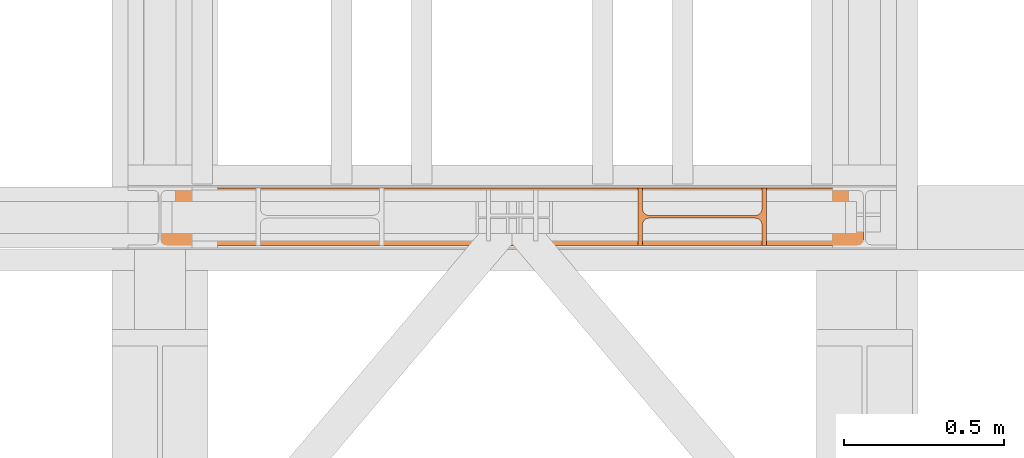
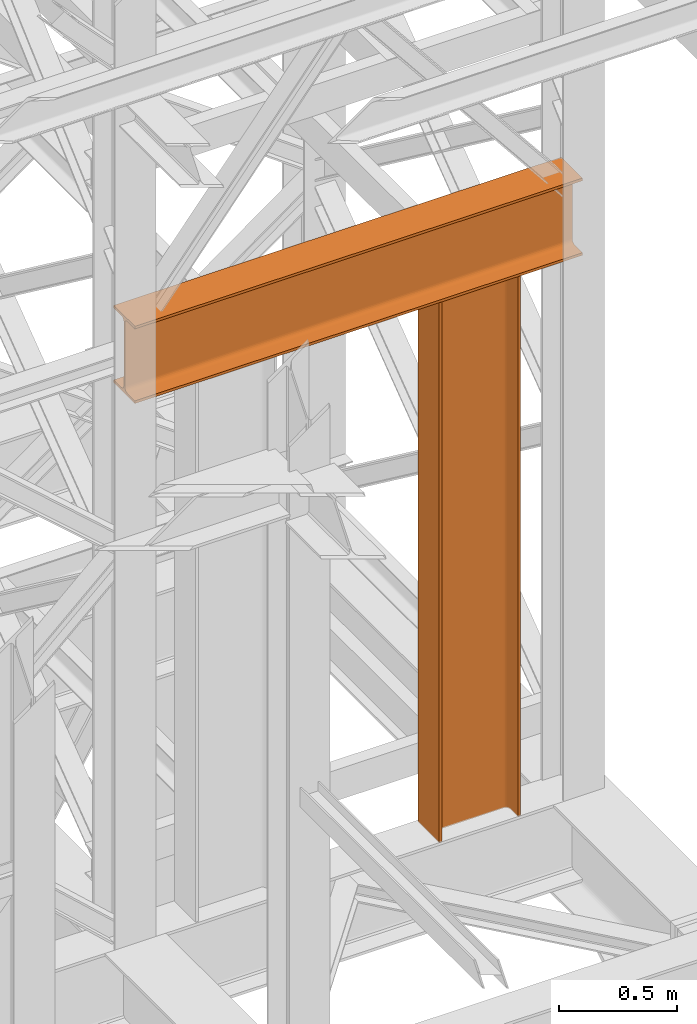
# One storey, part 177 of 208: 2 proxies.
"""IFC2X3 building model written with IfcOpenShell, lengths in millimetres."""

from ifc_helpers import new_model, entity, si_unit, converted_unit, frame, origin, origin_with_axes, place, context, subcontext, project, spatial, faceted_brep, element, save


model = new_model("IFC2X3")

# Units and contexts
model_context = context("Model", 3, precision=1e-05, world=origin())
plan_context = context("Plan", 3, precision=1e-05, world=origin())
body_context = subcontext(model_context, "Body", "Model", "MODEL_VIEW")
ifc_project = project(units=[si_unit("LENGTHUNIT", "METRE", prefix="MILLI"), converted_unit("PLANEANGLEUNIT", "DEGREE", entity("IfcPlaneAngleMeasure", 0.0174532925199433), si_unit("PLANEANGLEUNIT", "RADIAN"), dimensions=[0, 0, 0, 0, 0, 0, 0]), si_unit("AREAUNIT", "SQUARE_METRE"), si_unit("VOLUMEUNIT", "CUBIC_METRE")], contexts=[model_context, plan_context])

# Building, storey
building_placement = place(None, origin())
building = spatial("IfcBuilding", under=ifc_project, at=building_placement, CompositionType="COMPLEX")
storey_placement = place(building_placement, origin_with_axes())
storey = spatial("IfcBuildingStorey", under=building, at=storey_placement, Name="Geschoss", CompositionType="ELEMENT")

# Proxies
proxy_1_placement = place(storey_placement, frame((8086.754968394562, -16050.07439031789, 5278.356417081654), z_axis=(0.0, 0.0, 1.0), x_axis=(1.0, 0.0, 0.0)))
element("IfcBuildingElementProxy", 1, at=proxy_1_placement, inside=storey, context=body_context, shape_type="Brep", body=[
    faceted_brep([(0.01000000000021828, 180.0100000000002, 0.01000000000112777), (13.51000000000022, 180.0100000000002, 0.01000000000112777), (13.51000000000022, 180.0100000000002, 2800.009999999993), (0.01000000000021828, 180.0100000000002, 2800.009999999993), (13.51000000000022, 180.0100000000002, 0.01000000000112777), (13.51000000000022, 115.3100001907351, 0.01000000000112777), (13.51000000000022, 115.3100001907351, 2800.009999999993), (13.51000000000022, 180.0100000000002, 2800.009999999993), (13.51000000000022, 115.3100001907351, 0.01000000000112777), (14.53788471157623, 108.820665321733, 0.01000000000112777), (14.53788471157623, 108.820665321733, 2800.009999999993), (13.51000000000022, 115.3100001907351, 2800.009999999993), (14.53788471157623, 108.820665321733, 0.01000000000112777), (17.52066908402048, 102.9665306951119, 0.01000000000112777), (17.52066908402048, 102.9665306951119, 2800.009999999993), (14.53788471157623, 108.820665321733, 2800.009999999993), (17.52066908402048, 102.9665306951119, 0.01000000000112777), (22.16653050437617, 98.32066927475717, 0.01000000000112777), (22.16653050437617, 98.32066927475717, 2800.009999999993), (17.52066908402048, 102.9665306951119, 2800.009999999993), (22.16653050437617, 98.32066927475717, 0.01000000000112777), (28.02066513099726, 95.337884902312, 0.01000000000112777), (28.02066513099726, 95.337884902312, 2800.009999999993), (22.16653050437617, 98.32066927475717, 2800.009999999993), (28.02066513099726, 95.337884902312, 0.01000000000112777), (34.51000000000022, 94.31000019073508, 0.01000000000112777), (34.51000000000022, 94.31000019073508, 2800.009999999993), (28.02066513099726, 95.337884902312, 2800.009999999993), (34.51000000000022, 94.31000019073508, 0.01000000000112777), (365.5100000000002, 94.31000019073508, 0.01000000000021828), (365.5100000000002, 94.31000019073508, 2800.009999999993), (34.51000000000022, 94.31000019073508, 2800.009999999993), (365.5100000000002, 94.31000019073508, 0.01000000000021828), (371.9993348690023, 95.337884902312, 0.01000000000021828), (371.9993348690023, 95.337884902312, 2800.009999999993), (365.5100000000002, 94.31000019073508, 2800.009999999993), (371.9993348690023, 95.337884902312, 0.01000000000021828), (377.8534694956234, 98.32066927475717, 0.01000000000021828), (377.8534694956234, 98.32066927475717, 2800.009999999993), (371.9993348690023, 95.337884902312, 2800.009999999993), (377.8534694956234, 98.32066927475717, 0.01000000000021828), (382.49933091598, 102.9665306951119, 0.01000000000021828), (382.49933091598, 102.9665306951119, 2800.009999999993), (377.8534694956234, 98.32066927475717, 2800.009999999993), (382.49933091598, 102.9665306951119, 0.01000000000021828), (385.4821152884251, 108.820665321733, 0.01000000000021828), (385.4821152884251, 108.820665321733, 2800.009999999993), (382.49933091598, 102.9665306951119, 2800.009999999993), (385.4821152884251, 108.820665321733, 0.01000000000021828), (386.5100000000002, 115.3100001907351, 0.01000000000021828), (386.5100000000002, 115.3100001907351, 2800.009999999993), (385.4821152884251, 108.820665321733, 2800.009999999993), (386.5100000000002, 115.3100001907351, 0.01000000000021828), (386.5100000000002, 180.0100000000002, 0.01000000000021828), (386.5100000000002, 180.0100000000002, 2800.009999999993), (386.5100000000002, 115.3100001907351, 2800.009999999993), (386.5100000000002, 180.0100000000002, 0.01000000000021828), (400.0100000000002, 180.0100000000002, 0.01000000000021828), (400.0100000000002, 180.0100000000002, 2800.009999999993), (386.5100000000002, 180.0100000000002, 2800.009999999993), (400.0100000000002, 180.0100000000002, 0.01000000000021828), (400.0100000000002, 0.01000000000021828, 0.01000000000021828), (400.0100000000002, 0.01000000000021828, 2800.009999999993), (400.0100000000002, 180.0100000000002, 2800.009999999993), (400.0100000000002, 0.01000000000021828, 0.01000000000021828), (386.5100000000002, 0.01000000000021828, 0.01000000000021828), (386.5100000000002, 0.01000000000021828, 2800.009999999993), (400.0100000000002, 0.01000000000021828, 2800.009999999993), (386.5100000000002, 0.01000000000021828, 0.01000000000021828), (386.5100000000002, 64.70999980926535, 0.01000000000021828), (386.5100000000002, 64.70999980926535, 2800.009999999993), (386.5100000000002, 0.01000000000021828, 2800.009999999993), (386.5100000000002, 64.70999980926535, 0.01000000000021828), (385.4821152884251, 71.1993346782674, 0.01000000000021828), (385.4821152884251, 71.1993346782674, 2800.009999999993), (386.5100000000002, 64.70999980926535, 2800.009999999993), (385.4821152884251, 71.1993346782674, 0.01000000000021828), (382.49933091598, 77.0534693048885, 0.01000000000021828), (382.49933091598, 77.0534693048885, 2800.009999999993), (385.4821152884251, 71.1993346782674, 2800.009999999993), (382.49933091598, 77.0534693048885, 0.01000000000021828), (377.8534694956234, 81.69933072524327, 0.01000000000021828), (377.8534694956234, 81.69933072524327, 2800.009999999993), (382.49933091598, 77.0534693048885, 2800.009999999993), (377.8534694956234, 81.69933072524327, 0.01000000000021828), (371.9993348690023, 84.68211509768844, 0.01000000000021828), (371.9993348690023, 84.68211509768844, 2800.009999999993), (377.8534694956234, 81.69933072524327, 2800.009999999993), (371.9993348690023, 84.68211509768844, 0.01000000000021828), (365.5100000000002, 85.70999980926535, 0.01000000000021828), (365.5100000000002, 85.70999980926535, 2800.009999999993), (371.9993348690023, 84.68211509768844, 2800.009999999993), (365.5100000000002, 85.70999980926535, 0.01000000000021828), (34.51000000000022, 85.70999980926535, 0.01000000000112777), (34.51000000000022, 85.70999980926535, 2800.009999999993), (365.5100000000002, 85.70999980926535, 2800.009999999993), (34.51000000000022, 85.70999980926535, 0.01000000000112777), (29.07481828161781, 84.99438062176887, 0.01000000000112777), (29.07481828161781, 84.99438062176887, 2800.009999999993), (34.51000000000022, 85.70999980926535, 2800.009999999993), (29.07481828161781, 84.99438062176887, 0.01000000000112777), (24.01003062535619, 82.89647688400692, 0.01000000000112777), (24.01003062535619, 82.89647688400692, 2800.009999999993), (29.07481828161781, 84.99438062176887, 2800.009999999993), (24.01003062535619, 82.89647688400692, 0.01000000000112777), (19.66075759508203, 79.55924221418354, 0.01000000000112777), (19.66075759508203, 79.55924221418354, 2800.009999999993), (24.01003062535619, 82.89647688400692, 2800.009999999993), (19.66075759508203, 79.55924221418354, 0.01000000000112777), (16.32352292525866, 75.20996918390847, 0.01000000000112777), (16.32352292525866, 75.20996918390847, 2800.009999999993), (19.66075759508203, 79.55924221418354, 2800.009999999993), (16.32352292525866, 75.20996918390847, 0.01000000000112777), (14.22561918749489, 70.14518152764686, 0.01000000000112777), (14.22561918749489, 70.14518152764686, 2800.009999999993), (16.32352292525866, 75.20996918390847, 2800.009999999993), (14.22561918749489, 70.14518152764686, 0.01000000000112777), (13.51000000000022, 64.70999980926535, 0.01000000000112777), (13.51000000000022, 64.70999980926535, 2800.009999999993), (14.22561918749489, 70.14518152764686, 2800.009999999993), (13.51000000000022, 64.70999980926535, 0.01000000000112777), (13.51000000000022, 0.01000000000021828, 0.01000000000112777), (13.51000000000022, 0.01000000000021828, 2800.009999999993), (13.51000000000022, 64.70999980926535, 2800.009999999993), (13.51000000000022, 0.01000000000021828, 0.01000000000112777), (0.01000000000021828, 0.01000000000021828, 0.01000000000112777), (0.01000000000021828, 0.01000000000021828, 2800.009999999993), (13.51000000000022, 0.01000000000021828, 2800.009999999993), (0.01000000000021828, 0.01000000000021828, 0.01000000000112777), (0.01000000000021828, 180.0100000000002, 0.01000000000112777), (0.01000000000021828, 180.0100000000002, 2800.009999999993), (0.01000000000021828, 0.01000000000021828, 2800.009999999993), (0.01000000000021828, 180.0100000000002, 0.01000000000112777), (0.01000000000021828, 0.01000000000021828, 0.01000000000112777), (13.51000000000022, 0.01000000000021828, 0.01000000000112777), (13.51000000000022, 64.70999980926535, 0.01000000000112777), (14.22561918749489, 70.14518152764686, 0.01000000000112777), (16.32352292525866, 75.20996918390847, 0.01000000000112777), (19.66075759508203, 79.55924221418354, 0.01000000000112777), (24.01003062535619, 82.89647688400692, 0.01000000000112777), (29.07481828161781, 84.99438062176887, 0.01000000000112777), (34.51000000000022, 85.70999980926535, 0.01000000000112777), (365.5100000000002, 85.70999980926535, 0.01000000000021828), (371.9993348690023, 84.68211509768844, 0.01000000000021828), (377.8534694956234, 81.69933072524327, 0.01000000000021828), (382.49933091598, 77.0534693048885, 0.01000000000021828), (385.4821152884251, 71.1993346782674, 0.01000000000021828), (386.5100000000002, 64.70999980926535, 0.01000000000021828), (386.5100000000002, 0.01000000000021828, 0.01000000000021828), (400.0100000000002, 0.01000000000021828, 0.01000000000021828), (400.0100000000002, 180.0100000000002, 0.01000000000021828), (386.5100000000002, 180.0100000000002, 0.01000000000021828), (386.5100000000002, 115.3100001907351, 0.01000000000021828), (385.4821152884251, 108.820665321733, 0.01000000000021828), (382.49933091598, 102.9665306951119, 0.01000000000021828), (377.8534694956234, 98.32066927475717, 0.01000000000021828), (371.9993348690023, 95.337884902312, 0.01000000000021828), (365.5100000000002, 94.31000019073508, 0.01000000000021828), (34.51000000000022, 94.31000019073508, 0.01000000000112777), (28.02066513099726, 95.337884902312, 0.01000000000112777), (22.16653050437617, 98.32066927475717, 0.01000000000112777), (17.52066908402048, 102.9665306951119, 0.01000000000112777), (14.53788471157623, 108.820665321733, 0.01000000000112777), (13.51000000000022, 115.3100001907351, 0.01000000000112777), (13.51000000000022, 180.0100000000002, 0.01000000000112777), (0.01000000000021828, 180.0100000000002, 2800.009999999993), (13.51000000000022, 180.0100000000002, 2800.009999999993), (13.51000000000022, 115.3100001907351, 2800.009999999993), (14.53788471157623, 108.820665321733, 2800.009999999993), (17.52066908402048, 102.9665306951119, 2800.009999999993), (22.16653050437617, 98.32066927475717, 2800.009999999993), (28.02066513099726, 95.337884902312, 2800.009999999993), (34.51000000000022, 94.31000019073508, 2800.009999999993), (365.5100000000002, 94.31000019073508, 2800.009999999993), (371.9993348690023, 95.337884902312, 2800.009999999993), (377.8534694956234, 98.32066927475717, 2800.009999999993), (382.49933091598, 102.9665306951119, 2800.009999999993), (385.4821152884251, 108.820665321733, 2800.009999999993), (386.5100000000002, 115.3100001907351, 2800.009999999993), (386.5100000000002, 180.0100000000002, 2800.009999999993), (400.0100000000002, 180.0100000000002, 2800.009999999993), (400.0100000000002, 0.01000000000021828, 2800.009999999993), (386.5100000000002, 0.01000000000021828, 2800.009999999993), (386.5100000000002, 64.70999980926535, 2800.009999999993), (385.4821152884251, 71.1993346782674, 2800.009999999993), (382.49933091598, 77.0534693048885, 2800.009999999993), (377.8534694956234, 81.69933072524327, 2800.009999999993), (371.9993348690023, 84.68211509768844, 2800.009999999993), (365.5100000000002, 85.70999980926535, 2800.009999999993), (34.51000000000022, 85.70999980926535, 2800.009999999993), (29.07481828161781, 84.99438062176887, 2800.009999999993), (24.01003062535619, 82.89647688400692, 2800.009999999993), (19.66075759508203, 79.55924221418354, 2800.009999999993), (16.32352292525866, 75.20996918390847, 2800.009999999993), (14.22561918749489, 70.14518152764686, 2800.009999999993), (13.51000000000022, 64.70999980926535, 2800.009999999993), (13.51000000000022, 0.01000000000021828, 2800.009999999993), (0.01000000000021828, 0.01000000000021828, 2800.009999999993)], [[[0, 1, 2, 3]], [[4, 5, 6, 7]], [[8, 9, 10, 11]], [[12, 13, 14, 15]], [[16, 17, 18, 19]], [[20, 21, 22, 23]], [[24, 25, 26, 27]], [[28, 29, 30, 31]], [[32, 33, 34, 35]], [[36, 37, 38, 39]], [[40, 41, 42, 43]], [[44, 45, 46, 47]], [[48, 49, 50, 51]], [[52, 53, 54, 55]], [[56, 57, 58, 59]], [[60, 61, 62, 63]], [[64, 65, 66, 67]], [[68, 69, 70, 71]], [[72, 73, 74, 75]], [[76, 77, 78, 79]], [[80, 81, 82, 83]], [[84, 85, 86, 87]], [[88, 89, 90, 91]], [[92, 93, 94, 95]], [[96, 97, 98, 99]], [[100, 101, 102, 103]], [[104, 105, 106, 107]], [[108, 109, 110, 111]], [[112, 113, 114, 115]], [[116, 117, 118, 119]], [[120, 121, 122, 123]], [[124, 125, 126, 127]], [[128, 129, 130, 131]], [[132, 133, 134, 135, 136, 137, 138, 139, 140, 141, 142, 143, 144, 145, 146, 147, 148, 149, 150, 151, 152, 153, 154, 155, 156, 157, 158, 159, 160, 161, 162, 163, 164]], [[165, 166, 167, 168, 169, 170, 171, 172, 173, 174, 175, 176, 177, 178, 179, 180, 181, 182, 183, 184, 185, 186, 187, 188, 189, 190, 191, 192, 193, 194, 195, 196, 197]]], orient=[[False], [False], [False], [False], [False], [False], [False], [False], [False], [False], [False], [False], [False], [False], [False], [False], [False], [False], [False], [False], [False], [False], [False], [False], [False], [False], [False], [False], [False], [False], [False], [False], [False], [False], [False]]),
])
proxy_2_placement = place(storey_placement, frame((6595.42496483591, -16050.07439031789, 8078.356417081646), z_axis=(0.0, 0.0, 1.0), x_axis=(1.0, 0.0, 0.0)))
element("IfcBuildingElementProxy", 2, at=proxy_2_placement, inside=storey, context=body_context, shape_type="Brep", body=[
    faceted_brep([(2194.590003625702, 180.0100000000002, 400.0100000000002), (0.01000000000021828, 180.0100000000002, 400.0100000000002), (0.01000000000021828, 180.0100000000002, 386.5100000000002), (2194.590003625702, 180.0100000000002, 386.5100000000002), (2194.590003625702, 180.0100000000002, 386.5100000000002), (0.01000000000021828, 180.0100000000002, 386.5100000000002), (0.01000000000021828, 115.3100001907351, 386.5100000000002), (2194.590003625702, 115.3100001907351, 386.5100000000002), (2194.590003625702, 115.3100001907351, 386.5100000000002), (0.01000000000021828, 115.3100001907351, 386.5100000000002), (0.01000000000021828, 108.820665321733, 385.4821152884251), (2194.590003625702, 108.820665321733, 385.4821152884233), (2194.590003625702, 108.820665321733, 385.4821152884233), (0.01000000000021828, 108.820665321733, 385.4821152884251), (0.01000000000021828, 102.9665306951119, 382.4993309159818), (2194.590003625702, 102.9665306951119, 382.49933091598), (2194.590003625702, 102.9665306951119, 382.49933091598), (0.01000000000021828, 102.9665306951119, 382.4993309159818), (0.01000000000021828, 98.32066927475717, 377.8534694956252), (2194.590003625702, 98.32066927475717, 377.8534694956234), (2194.590003625702, 98.32066927475717, 377.8534694956234), (0.01000000000021828, 98.32066927475717, 377.8534694956252), (0.01000000000021828, 95.337884902312, 371.9993348690041), (2194.590003625702, 95.337884902312, 371.9993348690023), (2194.590003625702, 95.337884902312, 371.9993348690023), (0.01000000000021828, 95.337884902312, 371.9993348690041), (0.01000000000021828, 94.31000019073508, 365.5100000000002), (2194.590003625702, 94.31000019073508, 365.5100000000002), (2194.590003625702, 94.31000019073508, 365.5100000000002), (0.01000000000021828, 94.31000019073508, 365.5100000000002), (0.01000000000021828, 94.31000019073508, 34.51000000000113), (2194.590003625702, 94.31000019073508, 34.51000000000022), (2194.590003625702, 94.31000019073508, 34.51000000000022), (0.01000000000021828, 94.31000019073508, 34.51000000000113), (0.01000000000021828, 95.337884902312, 28.02066513099908), (2194.590003625702, 95.337884902312, 28.02066513099817), (2194.590003625702, 95.337884902312, 28.02066513099817), (0.01000000000021828, 95.337884902312, 28.02066513099908), (0.01000000000021828, 98.32066927475717, 22.16653050437799), (2194.590003625702, 98.32066927475717, 22.16653050437708), (2194.590003625702, 98.32066927475717, 22.16653050437708), (0.01000000000021828, 98.32066927475717, 22.16653050437799), (0.01000000000021828, 102.9665306951119, 17.5206690840223), (2194.590003625702, 102.9665306951119, 17.52066908402139), (2194.590003625702, 102.9665306951119, 17.52066908402139), (0.01000000000021828, 102.9665306951119, 17.5206690840223), (0.01000000000021828, 108.820665321733, 14.53788471157714), (2194.590003625702, 108.820665321733, 14.53788471157623), (2194.590003625702, 108.820665321733, 14.53788471157623), (0.01000000000021828, 108.820665321733, 14.53788471157714), (0.01000000000021828, 115.3100001907351, 13.51000000000113), (2194.590003625702, 115.3100001907351, 13.51000000000022), (2194.590003625702, 115.3100001907351, 13.51000000000022), (0.01000000000021828, 115.3100001907351, 13.51000000000113), (0.01000000000021828, 180.0100000000002, 13.51000000000113), (2194.590003625702, 180.0100000000002, 13.51000000000022), (2194.590003625702, 180.0100000000002, 13.51000000000022), (0.01000000000021828, 180.0100000000002, 13.51000000000113), (0.01000000000021828, 180.0100000000002, 0.01000000000112777), (2194.590003625702, 180.0100000000002, 0.01000000000021828), (2194.590003625702, 180.0100000000002, 0.01000000000021828), (0.01000000000021828, 180.0100000000002, 0.01000000000112777), (0.01000000000021828, 0.01000000000021828, 0.01000000000112777), (2194.590003625702, 0.01000000000021828, 0.01000000000021828), (2194.590003625702, 0.01000000000021828, 0.01000000000021828), (0.01000000000021828, 0.01000000000021828, 0.01000000000112777), (0.01000000000021828, 0.01000000000021828, 13.51000000000113), (2194.590003625702, 0.01000000000021828, 13.51000000000022), (2194.590003625702, 0.01000000000021828, 13.51000000000022), (0.01000000000021828, 0.01000000000021828, 13.51000000000113), (0.01000000000021828, 64.70999980926535, 13.51000000000113), (2194.590003625702, 64.70999980926535, 13.51000000000022), (2194.590003625702, 64.70999980926535, 13.51000000000022), (0.01000000000021828, 64.70999980926535, 13.51000000000113), (0.01000000000021828, 71.1993346782674, 14.53788471157714), (2194.590003625702, 71.1993346782674, 14.53788471157623), (2194.590003625702, 71.1993346782674, 14.53788471157623), (0.01000000000021828, 71.1993346782674, 14.53788471157714), (0.01000000000021828, 77.0534693048885, 17.5206690840223), (2194.590003625702, 77.0534693048885, 17.52066908402139), (2194.590003625702, 77.0534693048885, 17.52066908402139), (0.01000000000021828, 77.0534693048885, 17.5206690840223), (0.01000000000021828, 81.69933072524327, 22.16653050437799), (2194.590003625702, 81.69933072524327, 22.16653050437708), (2194.590003625702, 81.69933072524327, 22.16653050437708), (0.01000000000021828, 81.69933072524327, 22.16653050437799), (0.01000000000021828, 84.68211509768844, 28.02066513099908), (2194.590003625702, 84.68211509768844, 28.02066513099817), (2194.590003625702, 84.68211509768844, 28.02066513099817), (0.01000000000021828, 84.68211509768844, 28.02066513099908), (0.01000000000021828, 85.70999980926535, 34.51000000000113), (2194.590003625702, 85.70999980926535, 34.51000000000022), (2194.590003625702, 85.70999980926535, 34.51000000000022), (0.01000000000021828, 85.70999980926535, 34.51000000000113), (0.01000000000021828, 85.70999980926535, 365.5100000000002), (2194.590003625702, 85.70999980926535, 365.5100000000002), (2194.590003625702, 85.70999980926535, 365.5100000000002), (0.01000000000021828, 85.70999980926535, 365.5100000000002), (0.01000000000021828, 84.99438062176887, 370.9451817183835), (2194.590003625702, 84.99438062176887, 370.9451817183817), (2194.590003625702, 84.99438062176887, 370.9451817183817), (0.01000000000021828, 84.99438062176887, 370.9451817183835), (0.01000000000021828, 82.89647688400692, 376.0099693746452), (2194.590003625702, 82.89647688400692, 376.0099693746433), (2194.590003625702, 82.89647688400692, 376.0099693746433), (0.01000000000021828, 82.89647688400692, 376.0099693746452), (0.01000000000021828, 79.55924221418354, 380.3592424049184), (2194.590003625702, 79.55924221418354, 380.3592424049184), (2194.590003625702, 79.55924221418354, 380.3592424049184), (0.01000000000021828, 79.55924221418354, 380.3592424049184), (0.01000000000021828, 75.20996918390847, 383.6964770747418), (2194.590003625702, 75.20996918390847, 383.6964770747418), (2194.590003625702, 75.20996918390847, 383.6964770747418), (0.01000000000021828, 75.20996918390847, 383.6964770747418), (0.01000000000021828, 70.14518152764686, 385.7943808125074), (2194.590003625702, 70.14518152764686, 385.7943808125056), (2194.590003625702, 70.14518152764686, 385.7943808125056), (0.01000000000021828, 70.14518152764686, 385.7943808125074), (0.01000000000021828, 64.70999980926535, 386.5100000000002), (2194.590003625702, 64.70999980926535, 386.5100000000002), (2194.590003625702, 64.70999980926535, 386.5100000000002), (0.01000000000021828, 64.70999980926535, 386.5100000000002), (0.01000000000021828, 0.01000000000021828, 386.5100000000002), (2194.590003625702, 0.01000000000021828, 386.5100000000002), (2194.590003625702, 0.01000000000021828, 386.5100000000002), (0.01000000000021828, 0.01000000000021828, 386.5100000000002), (0.01000000000021828, 0.01000000000021828, 400.0100000000002), (2194.590003625702, 0.01000000000021828, 400.0100000000002), (2194.590003625702, 0.01000000000021828, 400.0100000000002), (0.01000000000021828, 0.01000000000021828, 400.0100000000002), (0.01000000000021828, 180.0100000000002, 400.0100000000002), (2194.590003625702, 180.0100000000002, 400.0100000000002), (2194.590003625702, 180.0100000000002, 400.0100000000002), (2194.590003625702, 180.0100000000002, 386.5100000000002), (2194.590003625702, 115.3100001907351, 386.5100000000002), (2194.590003625702, 108.820665321733, 385.4821152884233), (2194.590003625702, 102.9665306951119, 382.49933091598), (2194.590003625702, 98.32066927475717, 377.8534694956234), (2194.590003625702, 95.337884902312, 371.9993348690023), (2194.590003625702, 94.31000019073508, 365.5100000000002), (2194.590003625702, 94.31000019073508, 34.51000000000022), (2194.590003625702, 95.337884902312, 28.02066513099817), (2194.590003625702, 98.32066927475717, 22.16653050437708), (2194.590003625702, 102.9665306951119, 17.52066908402139), (2194.590003625702, 108.820665321733, 14.53788471157623), (2194.590003625702, 115.3100001907351, 13.51000000000022), (2194.590003625702, 180.0100000000002, 13.51000000000022), (2194.590003625702, 180.0100000000002, 0.01000000000021828), (2194.590003625702, 0.01000000000021828, 0.01000000000021828), (2194.590003625702, 0.01000000000021828, 13.51000000000022), (2194.590003625702, 64.70999980926535, 13.51000000000022), (2194.590003625702, 71.1993346782674, 14.53788471157623), (2194.590003625702, 77.0534693048885, 17.52066908402139), (2194.590003625702, 81.69933072524327, 22.16653050437708), (2194.590003625702, 84.68211509768844, 28.02066513099817), (2194.590003625702, 85.70999980926535, 34.51000000000022), (2194.590003625702, 85.70999980926535, 365.5100000000002), (2194.590003625702, 84.99438062176887, 370.9451817183817), (2194.590003625702, 82.89647688400692, 376.0099693746433), (2194.590003625702, 79.55924221418354, 380.3592424049184), (2194.590003625702, 75.20996918390847, 383.6964770747418), (2194.590003625702, 70.14518152764686, 385.7943808125056), (2194.590003625702, 64.70999980926535, 386.5100000000002), (2194.590003625702, 0.01000000000021828, 386.5100000000002), (2194.590003625702, 0.01000000000021828, 400.0100000000002), (0.01000000000021828, 180.0100000000002, 400.0100000000002), (0.01000000000021828, 0.01000000000021828, 400.0100000000002), (0.01000000000021828, 0.01000000000021828, 386.5100000000002), (0.01000000000021828, 64.70999980926535, 386.5100000000002), (0.01000000000021828, 70.14518152764686, 385.7943808125074), (0.01000000000021828, 75.20996918390847, 383.6964770747418), (0.01000000000021828, 79.55924221418354, 380.3592424049184), (0.01000000000021828, 82.89647688400692, 376.0099693746452), (0.01000000000021828, 84.99438062176887, 370.9451817183835), (0.01000000000021828, 85.70999980926535, 365.5100000000002), (0.01000000000021828, 85.70999980926535, 34.51000000000113), (0.01000000000021828, 84.68211509768844, 28.02066513099908), (0.01000000000021828, 81.69933072524327, 22.16653050437799), (0.01000000000021828, 77.0534693048885, 17.5206690840223), (0.01000000000021828, 71.1993346782674, 14.53788471157714), (0.01000000000021828, 64.70999980926535, 13.51000000000113), (0.01000000000021828, 0.01000000000021828, 13.51000000000113), (0.01000000000021828, 0.01000000000021828, 0.01000000000112777), (0.01000000000021828, 180.0100000000002, 0.01000000000112777), (0.01000000000021828, 180.0100000000002, 13.51000000000113), (0.01000000000021828, 115.3100001907351, 13.51000000000113), (0.01000000000021828, 108.820665321733, 14.53788471157714), (0.01000000000021828, 102.9665306951119, 17.5206690840223), (0.01000000000021828, 98.32066927475717, 22.16653050437799), (0.01000000000021828, 95.337884902312, 28.02066513099908), (0.01000000000021828, 94.31000019073508, 34.51000000000113), (0.01000000000021828, 94.31000019073508, 365.5100000000002), (0.01000000000021828, 95.337884902312, 371.9993348690041), (0.01000000000021828, 98.32066927475717, 377.8534694956252), (0.01000000000021828, 102.9665306951119, 382.4993309159818), (0.01000000000021828, 108.820665321733, 385.4821152884251), (0.01000000000021828, 115.3100001907351, 386.5100000000002), (0.01000000000021828, 180.0100000000002, 386.5100000000002)], [[[0, 1, 2, 3]], [[4, 5, 6, 7]], [[8, 9, 10, 11]], [[12, 13, 14, 15]], [[16, 17, 18, 19]], [[20, 21, 22, 23]], [[24, 25, 26, 27]], [[28, 29, 30, 31]], [[32, 33, 34, 35]], [[36, 37, 38, 39]], [[40, 41, 42, 43]], [[44, 45, 46, 47]], [[48, 49, 50, 51]], [[52, 53, 54, 55]], [[56, 57, 58, 59]], [[60, 61, 62, 63]], [[64, 65, 66, 67]], [[68, 69, 70, 71]], [[72, 73, 74, 75]], [[76, 77, 78, 79]], [[80, 81, 82, 83]], [[84, 85, 86, 87]], [[88, 89, 90, 91]], [[92, 93, 94, 95]], [[96, 97, 98, 99]], [[100, 101, 102, 103]], [[104, 105, 106, 107]], [[108, 109, 110, 111]], [[112, 113, 114, 115]], [[116, 117, 118, 119]], [[120, 121, 122, 123]], [[124, 125, 126, 127]], [[128, 129, 130, 131]], [[132, 133, 134, 135, 136, 137, 138, 139, 140, 141, 142, 143, 144, 145, 146, 147, 148, 149, 150, 151, 152, 153, 154, 155, 156, 157, 158, 159, 160, 161, 162, 163, 164]], [[165, 166, 167, 168, 169, 170, 171, 172, 173, 174, 175, 176, 177, 178, 179, 180, 181, 182, 183, 184, 185, 186, 187, 188, 189, 190, 191, 192, 193, 194, 195, 196, 197]]], orient=[[False], [False], [False], [False], [False], [False], [False], [False], [False], [False], [False], [False], [False], [False], [False], [False], [False], [False], [False], [False], [False], [False], [False], [False], [False], [False], [False], [False], [False], [False], [False], [False], [False], [False], [False]]),
])

save(model, "model.ifc")
